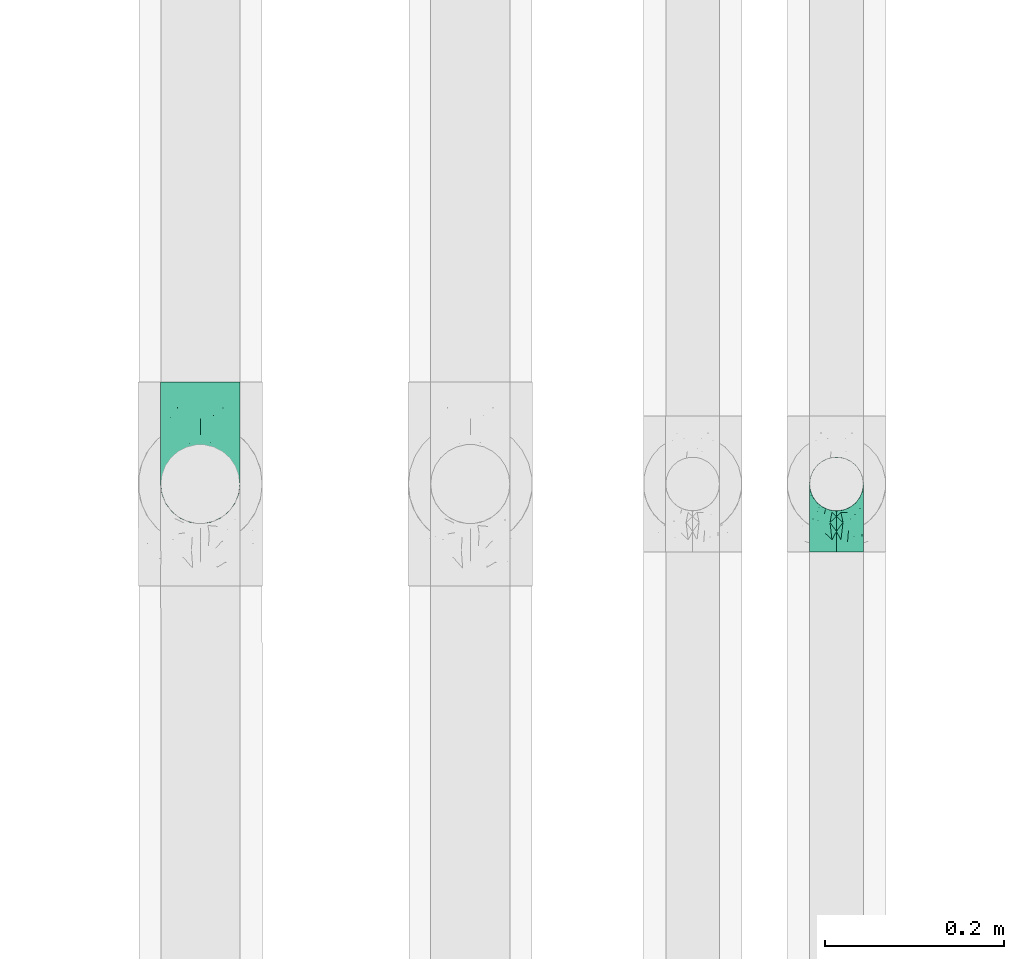
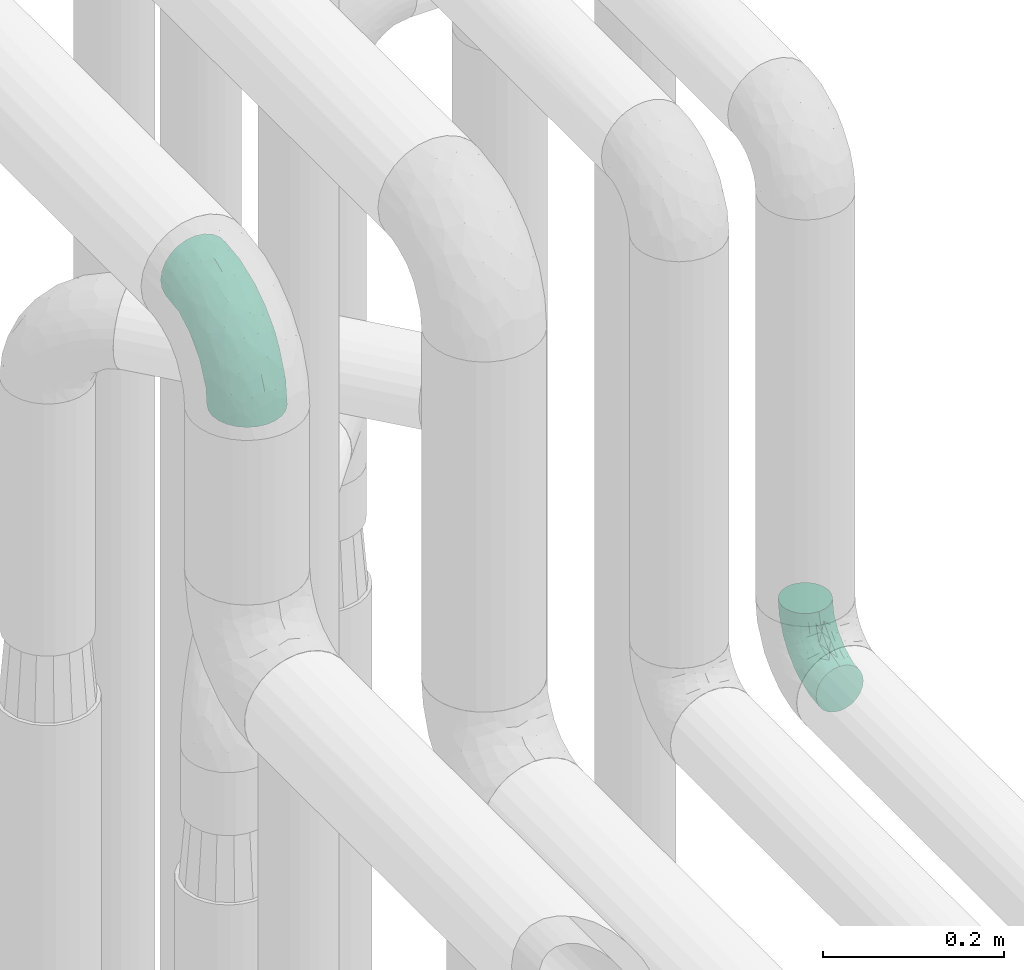
# One storey, part 796 of 827: 2 flow fittings.
"""IFC2X3 building model written with IfcOpenShell, lengths in millimetres."""

from ifc_helpers import new_model, entity, si_unit, converted_unit, derived_unit, direction, frame, origin, place, context, subcontext, project, spatial, faceted_brep, source, transform, mapped, material, type_object, type_shapes, element, save


model = new_model("IFC2X3")

# Units and contexts
model_context = context("Model", 3, precision=0.01, world=origin(), true_north=direction((6.12303176911189e-17, 1.0)))
body_context = subcontext(model_context, "Body", "Model", "MODEL_VIEW")
ifc_project = project(units=[si_unit("LENGTHUNIT", "METRE", prefix="MILLI"), si_unit("AREAUNIT", "SQUARE_METRE"), si_unit("VOLUMEUNIT", "CUBIC_METRE"), converted_unit("PLANEANGLEUNIT", "DEGREE", entity("IfcRatioMeasure", 0.0174532925199433), si_unit("PLANEANGLEUNIT", "RADIAN"), dimensions=[0, 0, 0, 0, 0, 0, 0]), si_unit("MASSUNIT", "GRAM", prefix="KILO"), derived_unit("MASSDENSITYUNIT", [(si_unit("MASSUNIT", "GRAM", prefix="KILO"), 1), (si_unit("LENGTHUNIT", "METRE"), -3)]), derived_unit("MOMENTOFINERTIAUNIT", [(si_unit("LENGTHUNIT", "METRE"), 4)]), si_unit("TIMEUNIT", "SECOND"), si_unit("FREQUENCYUNIT", "HERTZ"), si_unit("THERMODYNAMICTEMPERATUREUNIT", "DEGREE_CELSIUS"), derived_unit("THERMALTRANSMITTANCEUNIT", [(si_unit("MASSUNIT", "GRAM", prefix="KILO"), 1), (si_unit("THERMODYNAMICTEMPERATUREUNIT", "KELVIN"), -1), (si_unit("TIMEUNIT", "SECOND"), -3)]), derived_unit("VOLUMETRICFLOWRATEUNIT", [(si_unit("LENGTHUNIT", "METRE"), 3), (si_unit("TIMEUNIT", "SECOND"), -1)]), derived_unit("MASSFLOWRATEUNIT", [(si_unit("MASSUNIT", "GRAM", prefix="KILO"), 1), (si_unit("TIMEUNIT", "SECOND"), -1)]), derived_unit("ROTATIONALFREQUENCYUNIT", [(si_unit("TIMEUNIT", "SECOND"), -1)]), si_unit("ELECTRICCURRENTUNIT", "AMPERE"), si_unit("ELECTRICVOLTAGEUNIT", "VOLT"), si_unit("POWERUNIT", "WATT"), si_unit("FORCEUNIT", "NEWTON", prefix="KILO"), si_unit("ILLUMINANCEUNIT", "LUX"), si_unit("LUMINOUSFLUXUNIT", "LUMEN"), si_unit("LUMINOUSINTENSITYUNIT", "CANDELA"), derived_unit("USERDEFINED", [(si_unit("MASSUNIT", "GRAM", prefix="KILO"), -1), (si_unit("LENGTHUNIT", "METRE"), -2), (si_unit("TIMEUNIT", "SECOND"), 3), (si_unit("LUMINOUSFLUXUNIT", "LUMEN"), 1)]), derived_unit("LINEARVELOCITYUNIT", [(si_unit("LENGTHUNIT", "METRE"), 1), (si_unit("TIMEUNIT", "SECOND"), -1)]), si_unit("PRESSUREUNIT", "PASCAL"), derived_unit("USERDEFINED", [(si_unit("LENGTHUNIT", "METRE"), -2), (si_unit("MASSUNIT", "GRAM", prefix="KILO"), 1), (si_unit("TIMEUNIT", "SECOND"), -2)]), derived_unit("LINEARFORCEUNIT", [(si_unit("MASSUNIT", "GRAM", prefix="KILO"), 1), (si_unit("LENGTHUNIT", "METRE"), 1), (si_unit("TIMEUNIT", "SECOND"), -2), (si_unit("LENGTHUNIT", "METRE"), -1)]), derived_unit("PLANARFORCEUNIT", [(si_unit("MASSUNIT", "GRAM", prefix="KILO"), 1), (si_unit("LENGTHUNIT", "METRE"), 1), (si_unit("TIMEUNIT", "SECOND"), -2), (si_unit("LENGTHUNIT", "METRE"), -2)])], contexts=[model_context])

# Site, building, storey
site_placement = place(None, origin())
site = spatial("IfcSite", under=ifc_project, at=site_placement, CompositionType="ELEMENT")
building_placement = place(site_placement, origin())
building = spatial("IfcBuilding", under=site, at=building_placement, CompositionType="ELEMENT")
storey_placement = place(building_placement, frame((0.0, 0.0, 28200.0)))
storey = spatial("IfcBuildingStorey", under=building, at=storey_placement, Name="08", CompositionType="ELEMENT", Elevation=28200.0)

# Flow fittings
ifc_material = material()
pipe_fitting_type_1 = type_object("IfcPipeFittingType", Name="ADSK_1", PredefinedType="NOTDEFINED", material=ifc_material)
shared_shape_1 = source(origin(), body_context, "Body", "Brep", [
    faceted_brep([(-114.0, 22.22, -38.49), (-114.0, 11.5, -42.94), (-114.0, 0.0, -44.45), (-114.0, -11.5, -42.94), (-114.0, -22.23, -38.49), (-114.0, -31.43, -31.43), (-114.0, -38.49, -22.23), (-114.0, -42.94, -11.5), (-114.0, -44.45, 0.0), (-114.0, -42.94, 11.5), (-114.0, -38.49, 22.22), (-114.0, -31.43, 31.43), (-114.0, -22.23, 38.49), (-114.0, -11.5, 42.94), (-114.0, 0.0, 44.45), (-114.0, 11.5, 42.94), (-114.0, 22.22, 38.49), (-114.0, 31.43, 31.43), (-114.0, 38.49, 22.22), (-114.0, 42.94, 11.5), (-114.0, 44.45, 0.0), (-114.0, 42.94, -11.5), (-114.0, 38.49, -22.23), (-114.0, 31.43, -31.43), (-11.5, 114.0, -42.94), (-22.23, 114.0, -38.49), (-31.43, 114.0, -31.43), (-38.49, 114.0, -22.23), (-42.94, 114.0, -11.5), (-44.45, 114.0, 0.0), (-42.94, 114.0, 11.5), (-38.49, 114.0, 22.22), (-31.43, 114.0, 31.43), (-22.23, 114.0, 38.49), (-11.5, 114.0, 42.94), (0.0, 114.0, 44.45), (11.5, 114.0, 42.94), (22.22, 114.0, 38.49), (31.43, 114.0, 31.43), (38.49, 114.0, 22.22), (42.94, 114.0, 11.5), (44.45, 114.0, 0.0), (42.94, 114.0, -11.5), (38.49, 114.0, -22.23), (31.43, 114.0, -31.43), (22.22, 114.0, -38.49), (11.5, 114.0, -42.94), (0.0, 114.0, -44.45), (-24.5, -15.82, 8.24), (-7.18, -2.06, 7.97), (-13.53, -4.79, 15.72), (-92.03, -41.56, 0.0), (-77.08, -37.56, 14.57), (23.74, 74.96, 33.55), (-72.99, -39.05, 0.0), (-84.56, -15.6, 40.23), (-47.88, -6.37, 37.83), (-59.8, 2.77, 43.37), (-84.46, -33.54, 25.41), (16.69, 49.28, 31.02), (6.37, 47.88, 37.83), (3.35, 25.47, 29.77), (-47.43, 81.55, 19.51), (-74.96, -23.74, 33.55), (-46.77, -27.89, 11.23), (-53.88, -31.14, 0.0), (-87.05, 38.52, 28.81), (-63.44, 55.78, 24.79), (-93.24, 43.37, 18.58), (-16.67, 16.67, 37.64), (-25.47, -3.35, 29.77), (-17.2, 97.7, 41.53), (-7.42, 85.54, 44.3), (-67.09, 46.29, 31.23), (-18.08, 42.1, 44.06), (-32.93, 14.9, 42.17), (-11.54, 34.94, 41.69), (-95.7, 27.79, 36.14), (-88.55, -4.92, 43.79), (-2.77, 59.8, 43.37), (-87.65, 48.44, 9.87), (-81.01, 8.37, 44.32), (-37.63, 90.26, 28.6), (-51.29, 61.56, 30.59), (-29.32, 87.72, 36.52), (23.49, 49.5, 23.28), (8.19, 20.11, 19.18), (-70.06, 58.9, 9.01), (-87.38, 49.74, 0.0), (-88.15, 18.57, 41.8), (-7.96, 6.22, 24.33), (33.54, 84.46, 25.41), (37.56, 77.08, 14.57), (-58.37, 34.98, 40.92), (-62.38, 23.02, 43.45), (24.15, 39.93, 12.16), (31.14, 53.88, 0.0), (-58.13, 14.61, 44.45), (-37.17, 26.09, 44.37), (4.92, 88.55, 43.79), (-34.78, -23.22, 0.0), (-49.5, -23.49, 23.28), (41.56, 92.03, 0.0), (-57.83, 66.03, 19.12), (-71.84, 54.46, 17.06), (-46.46, 94.23, 8.51), (-49.74, 87.38, 0.0), (-38.96, 59.98, 38.88), (-55.29, 46.95, 36.83), (-64.82, 64.82, 0.0), (-55.88, 73.75, 10.01), (15.6, 84.56, 40.23), (-21.6, 76.38, 42.11), (-49.04, -15.53, 31.95), (-19.97, 55.59, 44.33), (-73.61, 33.95, 37.2), (-31.05, 58.14, 42.19), (-41.3, 41.3, 43.02), (-27.36, -11.22, 22.61), (9.28, 15.84, 8.73), (23.22, 34.78, 0.0), (39.05, 72.99, 0.0), (-1.96, 1.96, 0.0), (10.63, 18.37, 0.0), (-18.37, -10.63, 0.0), (-97.7, 17.2, -41.53), (9.28, 15.84, -8.73), (-13.53, -4.79, -15.72), (8.19, 20.11, -19.18), (-85.54, 7.42, -44.3), (-8.37, 81.01, -44.32), (-90.26, 37.63, -28.6), (-87.72, 29.32, -36.52), (-27.79, 95.7, -36.14), (-38.52, 87.05, -28.81), (-94.23, 46.46, -8.51), (-84.56, -15.6, -40.23), (-73.75, 55.88, -10.01), (-10.19, -4.86, -7.51), (-76.38, 21.6, -42.11), (-59.98, 38.96, -38.88), (-49.28, -16.69, -31.02), (-47.88, -6.37, -37.83), (-25.47, -3.35, -29.77), (-34.98, 58.37, -40.92), (-46.95, 55.29, -36.83), (-77.08, -37.56, -14.57), (-18.57, 88.15, -41.8), (-23.02, 62.38, -43.45), (-55.78, 63.44, -24.79), (-43.37, 93.24, -18.58), (-84.46, -33.54, -25.41), (-33.95, 73.61, -37.2), (-46.29, 67.09, -31.23), (-74.96, -23.74, -33.55), (-48.44, 87.65, -9.87), (-45.44, -27.06, -11.87), (-88.55, -4.92, -43.79), (-49.5, -23.49, -23.28), (-14.61, 58.13, -44.45), (-26.09, 37.17, -44.37), (15.6, 84.56, -40.23), (6.37, 47.88, -37.83), (-2.77, 59.8, -43.37), (-81.55, 47.43, -19.51), (33.54, 84.46, -25.41), (23.49, 49.5, -23.28), (23.74, 74.96, -33.55), (-42.1, 18.08, -44.06), (-14.9, 32.93, -42.17), (-34.94, 11.54, -41.69), (-61.56, 51.29, -30.59), (-27.36, -11.22, -22.61), (37.56, 77.08, -14.57), (4.92, 88.55, -43.79), (-59.8, 2.77, -43.37), (-66.03, 57.83, -19.12), (-54.46, 71.84, -17.06), (-55.59, 19.97, -44.33), (-58.9, 70.06, -9.01), (24.15, 39.93, -12.16), (15.53, 49.04, -31.95), (-58.14, 31.05, -42.19), (-41.3, 41.3, -43.02), (-16.67, 16.67, -37.64), (3.35, 25.47, -29.77), (-7.96, 6.22, -24.33), (-26.36, -16.33, -11.05)], [[[0, 1, 2, 3, 4, 5, 6, 7, 8, 9, 10, 11, 12, 13, 14, 15, 16, 17, 18, 19, 20, 21, 22, 23]], [[24, 25, 26, 27, 28, 29, 30, 31, 32, 33, 34, 35, 36, 37, 38, 39, 40, 41, 42, 43, 44, 45, 46, 47]], [[48, 49, 50]], [[51, 52, 9]], [[53, 38, 37]], [[9, 52, 10]], [[54, 52, 51]], [[55, 56, 57]], [[11, 10, 58]], [[59, 60, 61]], [[31, 30, 62]], [[63, 12, 11]], [[63, 55, 12]], [[64, 52, 65]], [[66, 67, 68]], [[69, 56, 70]], [[34, 71, 72]], [[67, 66, 73]], [[74, 75, 76]], [[16, 77, 17]], [[13, 78, 14]], [[76, 79, 74]], [[68, 80, 19]], [[18, 17, 66]], [[14, 78, 81]], [[20, 19, 80]], [[82, 83, 84]], [[85, 61, 86]], [[87, 88, 80]], [[18, 68, 19]], [[15, 89, 16]], [[14, 81, 15]], [[70, 90, 61]], [[17, 77, 66]], [[91, 85, 92]], [[93, 89, 94]], [[95, 96, 92]], [[84, 71, 33]], [[94, 97, 98]], [[36, 35, 99]], [[39, 38, 91]], [[39, 92, 40]], [[65, 100, 64]], [[91, 92, 39]], [[58, 101, 63]], [[92, 102, 40]], [[92, 85, 95]], [[67, 103, 104]], [[33, 32, 84]], [[105, 62, 30]], [[52, 58, 10]], [[106, 105, 29]], [[93, 107, 108]], [[106, 109, 110]], [[53, 111, 60]], [[84, 112, 71]], [[84, 107, 112]], [[32, 82, 84]], [[12, 55, 13]], [[113, 56, 63]], [[111, 37, 36]], [[33, 71, 34]], [[35, 34, 72]], [[112, 114, 72]], [[110, 105, 106]], [[111, 53, 37]], [[115, 108, 73]], [[89, 15, 81]], [[104, 87, 80]], [[110, 87, 103]], [[32, 31, 82]], [[116, 107, 117]], [[112, 116, 114]], [[99, 72, 79]], [[56, 55, 63]], [[78, 55, 57]], [[101, 118, 113]], [[56, 69, 75]], [[99, 111, 36]], [[79, 76, 60]], [[79, 60, 111]], [[60, 69, 61]], [[101, 58, 52]], [[63, 11, 58]], [[38, 53, 91]], [[85, 91, 53]], [[94, 89, 81]], [[77, 89, 115]], [[84, 83, 107]], [[93, 108, 115]], [[98, 114, 117]], [[79, 72, 114]], [[98, 117, 94]], [[98, 57, 75]], [[31, 62, 82]], [[83, 82, 62]], [[70, 113, 118]], [[61, 85, 59]], [[48, 64, 100]], [[95, 119, 120]], [[69, 70, 61]], [[70, 118, 90]], [[72, 99, 35]], [[111, 99, 79]], [[55, 78, 13]], [[81, 78, 57]], [[94, 81, 97]], [[93, 94, 117]], [[66, 68, 18]], [[80, 68, 104]], [[103, 87, 104]], [[80, 88, 20]], [[50, 49, 119]], [[95, 85, 86]], [[119, 95, 86]], [[121, 92, 96]], [[50, 119, 86]], [[119, 122, 123, 120]], [[110, 109, 87]], [[88, 87, 109]], [[62, 105, 110]], [[29, 105, 30]], [[81, 57, 97]], [[57, 98, 97]], [[107, 93, 117]], [[89, 93, 115]], [[107, 83, 108]], [[73, 108, 83]], [[67, 73, 83]], [[115, 73, 66]], [[103, 83, 62]], [[67, 104, 68]], [[83, 103, 67]], [[110, 103, 62]], [[89, 77, 16]], [[66, 77, 115]], [[56, 75, 57]], [[76, 75, 69]], [[60, 76, 69]], [[79, 114, 74]], [[114, 98, 74]], [[75, 74, 98]], [[9, 8, 51]], [[102, 92, 121]], [[102, 41, 40]], [[72, 71, 112]], [[52, 54, 65]], [[64, 48, 118]], [[101, 52, 64]], [[124, 122, 49]], [[118, 48, 50]], [[49, 48, 124]], [[119, 49, 122]], [[48, 100, 124]], [[114, 116, 117]], [[112, 107, 116]], [[101, 113, 63]], [[70, 56, 113]], [[64, 118, 101]], [[90, 50, 86]], [[50, 90, 118]], [[61, 90, 86]], [[85, 53, 59]], [[60, 59, 53]], [[95, 120, 96]], [[125, 1, 0]], [[126, 127, 128]], [[2, 1, 129]], [[47, 130, 24]], [[131, 132, 23]], [[26, 133, 134]], [[88, 135, 20]], [[136, 4, 3]], [[88, 109, 137]], [[138, 122, 124]], [[139, 132, 140]], [[141, 142, 143]], [[144, 140, 145]], [[125, 132, 139]], [[6, 146, 7]], [[144, 147, 148]], [[146, 51, 7]], [[134, 149, 150]], [[146, 6, 151]], [[152, 145, 153]], [[154, 4, 136]], [[154, 136, 142]], [[150, 155, 28]], [[42, 41, 102]], [[65, 146, 156]], [[0, 23, 132]], [[157, 3, 2]], [[146, 151, 158]], [[148, 159, 160]], [[161, 162, 163]], [[135, 164, 21]], [[165, 166, 167]], [[168, 169, 170]], [[147, 24, 130]], [[171, 132, 131]], [[155, 29, 28]], [[172, 141, 143]], [[134, 27, 26]], [[149, 134, 153]], [[173, 165, 43]], [[25, 24, 147]], [[22, 21, 164]], [[47, 174, 130]], [[133, 26, 25]], [[170, 175, 168]], [[47, 46, 174]], [[44, 167, 45]], [[27, 150, 28]], [[1, 125, 129]], [[156, 100, 65]], [[165, 44, 43]], [[161, 45, 167]], [[173, 43, 42]], [[6, 5, 151]], [[173, 102, 121]], [[137, 135, 88]], [[45, 161, 46]], [[102, 173, 42]], [[149, 176, 177]], [[172, 158, 141]], [[139, 178, 129]], [[154, 5, 4]], [[156, 146, 158]], [[106, 155, 179]], [[173, 96, 180]], [[181, 162, 167]], [[177, 179, 155]], [[137, 179, 176]], [[23, 22, 131]], [[182, 140, 183]], [[139, 182, 178]], [[157, 129, 175]], [[157, 136, 3]], [[175, 170, 142]], [[175, 142, 136]], [[142, 184, 143]], [[162, 161, 167]], [[174, 161, 163]], [[181, 166, 185]], [[162, 184, 169]], [[5, 154, 151]], [[158, 151, 154]], [[166, 165, 173]], [[167, 44, 165]], [[148, 147, 130]], [[133, 147, 152]], [[132, 171, 140]], [[144, 145, 152]], [[160, 178, 183]], [[175, 129, 178]], [[160, 183, 148]], [[160, 163, 169]], [[22, 164, 131]], [[171, 131, 164]], [[162, 185, 184]], [[186, 127, 172]], [[185, 128, 186]], [[156, 187, 100]], [[185, 166, 128]], [[143, 184, 185]], [[129, 157, 2]], [[136, 157, 175]], [[161, 174, 46]], [[130, 174, 163]], [[148, 130, 159]], [[144, 148, 183]], [[134, 150, 27]], [[155, 150, 177]], [[176, 179, 177]], [[155, 106, 29]], [[166, 180, 128]], [[128, 180, 126]], [[173, 180, 166]], [[126, 120, 123, 122]], [[120, 126, 180]], [[122, 138, 126]], [[137, 109, 179]], [[106, 179, 109]], [[164, 135, 137]], [[20, 135, 21]], [[130, 163, 159]], [[163, 160, 159]], [[140, 144, 183]], [[147, 144, 152]], [[140, 171, 145]], [[153, 145, 171]], [[149, 153, 171]], [[152, 153, 134]], [[176, 171, 164]], [[149, 177, 150]], [[171, 176, 149]], [[137, 176, 164]], [[147, 133, 25]], [[134, 133, 152]], [[162, 169, 163]], [[170, 169, 184]], [[142, 170, 184]], [[175, 178, 168]], [[178, 160, 168]], [[169, 168, 160]], [[51, 146, 54]], [[51, 8, 7]], [[132, 125, 0]], [[129, 125, 139]], [[156, 158, 172]], [[65, 54, 146]], [[178, 182, 183]], [[139, 140, 182]], [[158, 154, 141]], [[142, 141, 154]], [[186, 172, 143]], [[172, 127, 187]], [[185, 186, 143]], [[127, 186, 128]], [[187, 127, 138]], [[124, 100, 187]], [[126, 138, 127]], [[187, 138, 124]], [[172, 187, 156]], [[166, 181, 167]], [[185, 162, 181]], [[96, 173, 121]], [[96, 120, 180]]]),
])
type_shapes(pipe_fitting_type_1, [shared_shape_1])
flow_fitting_1_placement = place(storey_placement, frame((35918.07, 8807.39, 3550.0), z_axis=(1.0, 0.0, 0.0), x_axis=(0.0, -1.0, 1.09797795276059e-07)))
element("IfcFlowFitting", 1, at=flow_fitting_1_placement, inside=storey, type_object=pipe_fitting_type_1, material=ifc_material, Name="ADSK_1", ObjectType="ADSK_1", context=body_context, shape_type="MappedRepresentation", body=[
    mapped(shared_shape_1, transform((0.0, 0.0, 0.0), scale=1.0)),
])
pipe_fitting_type_2 = type_object("IfcPipeFittingType", Name="ADSK_1", PredefinedType="NOTDEFINED", material=ifc_material)
shared_shape_2 = source(origin(), body_context, "Body", "Brep", [
    faceted_brep([(-76.0, 15.07, -26.11), (-76.0, 7.8, -29.12), (-76.0, 0.0, -30.15), (-76.0, -7.8, -29.12), (-76.0, -15.08, -26.11), (-76.0, -21.32, -21.32), (-76.0, -26.11, -15.08), (-76.0, -29.12, -7.8), (-76.0, -30.15, 0.0), (-76.0, -29.12, 7.8), (-76.0, -26.11, 15.07), (-76.0, -21.32, 21.32), (-76.0, -15.08, 26.11), (-76.0, -7.8, 29.12), (-76.0, 0.0, 30.15), (-76.0, 7.8, 29.12), (-76.0, 15.07, 26.11), (-76.0, 21.32, 21.32), (-76.0, 26.11, 15.07), (-76.0, 29.12, 7.8), (-76.0, 30.15, 0.0), (-76.0, 29.12, -7.8), (-76.0, 26.11, -15.08), (-76.0, 21.32, -21.32), (0.0, 76.0, -30.15), (-7.8, 76.0, -29.12), (-15.07, 76.0, -26.11), (-21.32, 76.0, -21.32), (-26.11, 76.0, -15.08), (-29.12, 76.0, -7.8), (-30.15, 76.0, 0.0), (-29.12, 76.0, 7.8), (-26.11, 76.0, 15.07), (-21.32, 76.0, 21.32), (-15.07, 76.0, 26.11), (-7.8, 76.0, 29.12), (0.0, 76.0, 30.15), (7.8, 76.0, 29.12), (15.08, 76.0, 26.11), (21.32, 76.0, 21.32), (26.11, 76.0, 15.07), (29.12, 76.0, 7.8), (30.15, 76.0, 0.0), (29.12, 76.0, -7.8), (26.11, 76.0, -15.08), (21.32, 76.0, -21.32), (15.08, 76.0, -26.11), (7.8, 76.0, -29.12), (10.79, 31.43, 21.07), (4.32, 31.7, 25.72), (1.65, 15.19, 19.92), (-61.17, -27.8, 0.0), (-51.1, -25.49, 9.84), (-56.14, -10.61, 27.27), (-31.7, -4.32, 25.72), (-39.75, 1.72, 29.41), (-43.2, -24.95, 0.0), (-1.86, 1.86, 0.0), (4.49, 7.65, 5.78), (-7.82, -4.61, 5.83), (-56.21, -22.79, 17.21), (-58.98, -3.38, 29.7), (-53.96, 5.6, 30.07), (-10.86, 10.86, 25.48), (-17.2, -2.6, 20.44), (-49.15, -16.01, 22.7), (-22.18, -14.24, 7.99), (-28.4, -17.42, 0.0), (-13.61, -9.88, 0.0), (-39.0, 23.48, 27.76), (-58.76, 12.54, 28.36), (-41.61, 15.41, 29.48), (16.01, 49.15, 22.7), (-58.55, 25.93, 19.53), (-51.53, 33.5, 13.51), (-64.92, 28.76, 12.4), (-7.48, 23.14, 28.25), (-1.72, 39.75, 29.41), (-12.04, 27.88, 29.88), (-63.91, 18.81, 24.52), (-11.63, 65.16, 28.18), (-4.97, 57.02, 30.05), (9.88, 13.61, 0.0), (-62.5, 31.74, 5.02), (-45.17, 30.98, 21.2), (-21.78, 9.76, 28.58), (10.61, 56.14, 27.27), (-32.09, 54.42, 13.26), (22.79, 56.21, 17.21), (15.38, 31.17, 15.63), (25.49, 51.1, 9.84), (21.84, 36.35, 5.92), (24.95, 43.2, 0.0), (3.38, 58.98, 29.7), (-31.17, -15.38, 15.63), (-39.39, 41.78, 15.45), (-34.56, 41.13, 20.79), (-39.81, -23.25, 5.49), (27.8, 61.17, 0.0), (-31.74, 62.5, 5.02), (-53.07, 36.29, 0.0), (-42.95, 42.95, 7.29), (-36.29, 53.07, 0.0), (-19.83, 58.51, 24.79), (-25.48, 60.2, 19.41), (-14.53, 50.96, 28.57), (-13.31, 37.09, 30.07), (-26.16, 40.06, 26.4), (-32.43, -10.35, 21.9), (17.42, 28.4, 0.0), (14.24, 22.18, 7.99), (-38.67, 9.72, 30.15), (-24.66, 17.36, 30.09), (-37.08, 31.49, 24.99), (-49.27, 22.83, 25.24), (-20.8, 38.81, 28.63), (-27.58, 27.58, 29.2), (-36.07, -20.23, 10.71), (-15.19, -6.16, 14.9), (6.6, 15.4, 14.49), (-2.51, 2.51, 11.35), (-65.16, 11.63, -28.18), (-49.15, -16.01, -22.7), (-57.02, 4.97, -30.05), (-25.93, 58.55, -19.53), (-33.5, 51.53, -13.51), (-28.76, 64.92, -12.4), (-60.2, 25.48, -19.41), (-58.51, 19.83, -24.79), (-7.65, -4.49, -5.78), (-62.5, 31.74, -5.02), (-50.96, 14.53, -28.57), (-37.09, 13.31, -30.07), (-42.95, 42.95, -7.29), (25.49, 51.1, -9.84), (22.79, 56.21, -17.21), (-40.06, 26.16, -26.4), (3.38, 58.98, -29.7), (-5.6, 53.96, -30.07), (-27.88, 12.04, -29.88), (-9.76, 21.78, -28.58), (-23.14, 7.48, -28.25), (-51.1, -25.49, -9.84), (15.38, 31.17, -15.63), (16.01, 49.15, -22.7), (-23.48, 39.0, -27.76), (-12.54, 58.76, -28.36), (-15.41, 41.61, -29.48), (-56.21, -22.79, -17.21), (-9.72, 38.67, -30.15), (-17.36, 24.66, -30.09), (-22.18, -14.24, -7.99), (-41.13, 34.56, -20.79), (-31.74, 62.5, -5.02), (-58.98, -3.38, -29.7), (-31.17, -15.38, -15.63), (-56.14, -10.61, -27.27), (14.24, 22.18, -7.99), (23.25, 39.81, -5.49), (-31.49, 37.08, -24.99), (4.61, 7.82, -5.83), (-15.19, -6.16, -14.9), (1.65, 15.19, -19.92), (-2.51, 2.51, -11.35), (-18.81, 63.91, -24.52), (-32.59, -11.62, -20.84), (-31.7, -4.32, -25.72), (-17.2, -2.6, -20.44), (-39.75, 1.72, -29.41), (-54.42, 32.09, -13.26), (-30.98, 45.17, -21.2), (10.61, 56.14, -27.27), (10.23, 31.31, -21.52), (4.32, 31.7, -25.72), (-41.78, 39.39, -15.45), (-1.72, 39.75, -29.41), (-36.35, -21.84, -5.92), (-22.83, 49.27, -25.24), (-38.81, 20.8, -28.63), (-27.58, 27.58, -29.2), (-10.86, 10.86, -25.48), (20.23, 36.07, -10.71), (6.6, 15.4, -14.49)], [[[0, 1, 2, 3, 4, 5, 6, 7, 8, 9, 10, 11, 12, 13, 14, 15, 16, 17, 18, 19, 20, 21, 22, 23]], [[24, 25, 26, 27, 28, 29, 30, 31, 32, 33, 34, 35, 36, 37, 38, 39, 40, 41, 42, 43, 44, 45, 46, 47]], [[48, 49, 50]], [[51, 52, 9]], [[53, 54, 55]], [[9, 52, 10]], [[56, 52, 51]], [[57, 58, 59]], [[11, 10, 60]], [[14, 61, 62]], [[63, 54, 64]], [[65, 12, 11]], [[65, 53, 12]], [[66, 67, 68]], [[69, 70, 71]], [[72, 39, 38]], [[73, 74, 75]], [[15, 70, 16]], [[76, 77, 78]], [[16, 79, 17]], [[13, 61, 14]], [[35, 80, 81]], [[14, 62, 15]], [[17, 73, 18]], [[58, 57, 82]], [[20, 19, 83]], [[75, 19, 18]], [[70, 15, 62]], [[73, 84, 74]], [[78, 85, 76]], [[38, 86, 72]], [[32, 31, 87]], [[88, 89, 90]], [[91, 92, 90]], [[72, 86, 49]], [[36, 93, 37]], [[75, 83, 19]], [[36, 35, 81]], [[60, 94, 65]], [[40, 90, 41]], [[95, 96, 87]], [[88, 90, 40]], [[66, 97, 67]], [[90, 98, 41]], [[40, 39, 88]], [[99, 31, 30]], [[20, 83, 100]], [[101, 102, 100]], [[52, 60, 10]], [[102, 99, 30]], [[96, 103, 104]], [[83, 101, 100]], [[12, 53, 13]], [[104, 103, 33]], [[105, 106, 81]], [[107, 105, 103]], [[64, 54, 108]], [[80, 103, 105]], [[80, 35, 34]], [[34, 33, 103]], [[86, 38, 37]], [[109, 110, 82]], [[71, 111, 112]], [[69, 107, 113]], [[79, 73, 17]], [[114, 113, 84]], [[33, 32, 104]], [[115, 107, 116]], [[105, 115, 106]], [[93, 81, 77]], [[54, 53, 65]], [[61, 53, 55]], [[108, 94, 64]], [[54, 63, 85]], [[93, 86, 37]], [[77, 76, 49]], [[77, 49, 86]], [[49, 63, 50]], [[60, 52, 117]], [[65, 11, 60]], [[39, 72, 88]], [[89, 88, 72]], [[71, 70, 62]], [[79, 70, 114]], [[103, 96, 107]], [[69, 113, 114]], [[112, 106, 116]], [[77, 81, 106]], [[112, 116, 71]], [[112, 55, 85]], [[64, 50, 63]], [[57, 59, 68]], [[32, 87, 104]], [[96, 104, 87]], [[94, 118, 64]], [[50, 119, 89]], [[50, 64, 118]], [[50, 89, 48]], [[81, 93, 36]], [[86, 93, 77]], [[53, 61, 13]], [[62, 61, 55]], [[71, 62, 111]], [[69, 71, 116]], [[95, 101, 74]], [[99, 101, 87]], [[118, 66, 59]], [[117, 97, 66]], [[117, 66, 94]], [[91, 89, 110]], [[91, 110, 109]], [[110, 89, 119]], [[9, 8, 51]], [[98, 90, 92]], [[98, 42, 41]], [[101, 83, 74]], [[101, 99, 102]], [[87, 31, 99]], [[62, 55, 111]], [[55, 112, 111]], [[107, 69, 116]], [[70, 69, 114]], [[107, 96, 113]], [[84, 113, 96]], [[84, 96, 95]], [[114, 84, 73]], [[70, 79, 16]], [[73, 79, 114]], [[54, 85, 55]], [[76, 85, 63]], [[49, 76, 63]], [[77, 106, 78]], [[106, 112, 78]], [[85, 78, 112]], [[73, 75, 18]], [[83, 75, 74]], [[103, 80, 34]], [[81, 80, 105]], [[101, 95, 87]], [[84, 95, 74]], [[106, 115, 116]], [[105, 107, 115]], [[110, 119, 58]], [[110, 58, 82]], [[58, 120, 59]], [[118, 59, 120]], [[66, 68, 59]], [[54, 65, 108]], [[94, 108, 65]], [[66, 118, 94]], [[50, 118, 120]], [[50, 120, 119]], [[119, 120, 58]], [[89, 72, 48]], [[49, 48, 72]], [[60, 117, 94]], [[117, 52, 97]], [[52, 56, 97]], [[67, 97, 56]], [[92, 91, 109]], [[89, 91, 90]], [[121, 1, 0]], [[122, 5, 4]], [[2, 1, 123]], [[124, 125, 126]], [[127, 128, 23]], [[129, 57, 68]], [[100, 130, 20]], [[131, 132, 123]], [[133, 100, 102]], [[134, 135, 44]], [[131, 128, 136]], [[24, 137, 138]], [[139, 140, 141]], [[121, 128, 131]], [[6, 142, 7]], [[135, 143, 144]], [[142, 51, 7]], [[145, 146, 147]], [[142, 6, 148]], [[147, 149, 150]], [[151, 68, 67]], [[152, 128, 127]], [[30, 153, 102]], [[43, 42, 98]], [[154, 3, 2]], [[155, 142, 148]], [[156, 4, 3]], [[24, 138, 25]], [[153, 133, 102]], [[157, 158, 109]], [[30, 29, 153]], [[145, 136, 159]], [[27, 124, 28]], [[57, 160, 82]], [[161, 162, 163]], [[27, 26, 164]], [[146, 26, 25]], [[165, 166, 167]], [[24, 47, 137]], [[141, 168, 139]], [[22, 21, 169]], [[125, 124, 170]], [[146, 25, 138]], [[46, 144, 171]], [[156, 122, 4]], [[0, 23, 128]], [[1, 121, 123]], [[109, 82, 157]], [[45, 44, 135]], [[144, 46, 45]], [[134, 43, 98]], [[130, 21, 20]], [[134, 98, 92]], [[172, 173, 144]], [[46, 171, 47]], [[43, 134, 44]], [[174, 152, 169]], [[171, 173, 175]], [[6, 5, 148]], [[126, 29, 28]], [[176, 56, 142]], [[122, 156, 166]], [[164, 124, 27]], [[177, 159, 170]], [[23, 22, 127]], [[178, 136, 179]], [[131, 178, 132]], [[154, 123, 168]], [[154, 156, 3]], [[168, 141, 166]], [[168, 166, 156]], [[166, 180, 167]], [[173, 171, 144]], [[137, 171, 175]], [[172, 143, 162]], [[173, 180, 140]], [[5, 122, 148]], [[155, 148, 122]], [[135, 134, 181]], [[144, 45, 135]], [[147, 146, 138]], [[164, 146, 177]], [[128, 152, 136]], [[145, 159, 177]], [[150, 132, 179]], [[168, 123, 132]], [[150, 179, 147]], [[150, 175, 140]], [[57, 129, 160]], [[155, 165, 167]], [[22, 169, 127]], [[152, 127, 169]], [[162, 167, 180]], [[161, 155, 167]], [[173, 162, 180]], [[182, 162, 143]], [[123, 154, 2]], [[156, 154, 168]], [[171, 137, 47]], [[138, 137, 175]], [[147, 138, 149]], [[145, 147, 179]], [[174, 133, 125]], [[130, 133, 169]], [[176, 155, 151]], [[176, 151, 67]], [[151, 155, 161]], [[182, 157, 160]], [[181, 158, 157]], [[181, 157, 143]], [[51, 142, 56]], [[51, 8, 7]], [[133, 130, 100]], [[169, 21, 130]], [[126, 153, 29]], [[133, 153, 125]], [[138, 175, 149]], [[175, 150, 149]], [[136, 145, 179]], [[146, 145, 177]], [[136, 152, 159]], [[170, 159, 152]], [[170, 152, 174]], [[177, 170, 124]], [[146, 164, 26]], [[124, 164, 177]], [[173, 140, 175]], [[141, 140, 180]], [[166, 141, 180]], [[168, 132, 139]], [[132, 150, 139]], [[140, 139, 150]], [[124, 126, 28]], [[153, 126, 125]], [[128, 121, 0]], [[123, 121, 131]], [[133, 174, 169]], [[170, 174, 125]], [[132, 178, 179]], [[131, 136, 178]], [[163, 160, 129]], [[68, 151, 129]], [[161, 129, 151]], [[182, 160, 163]], [[157, 82, 160]], [[155, 122, 165]], [[166, 165, 122]], [[162, 161, 167]], [[161, 163, 129]], [[143, 172, 144]], [[162, 173, 172]], [[157, 182, 143]], [[163, 162, 182]], [[56, 176, 67]], [[155, 176, 142]], [[135, 181, 143]], [[181, 134, 158]], [[134, 92, 158]], [[109, 158, 92]]]),
])
type_shapes(pipe_fitting_type_2, [shared_shape_2])
flow_fitting_2_placement = place(storey_placement, frame((36629.64, 8807.39, 2850.0), z_axis=(-1.0, 0.0, 0.0), x_axis=(0.0, 0.0, -1.0)))
element("IfcFlowFitting", 2, at=flow_fitting_2_placement, inside=storey, type_object=pipe_fitting_type_2, material=ifc_material, Name="ADSK_1", ObjectType="ADSK_1", context=body_context, shape_type="MappedRepresentation", body=[
    mapped(shared_shape_2, transform((0.0, 0.0, 0.0), scale=1.0)),
])

save(model, "model.ifc")
